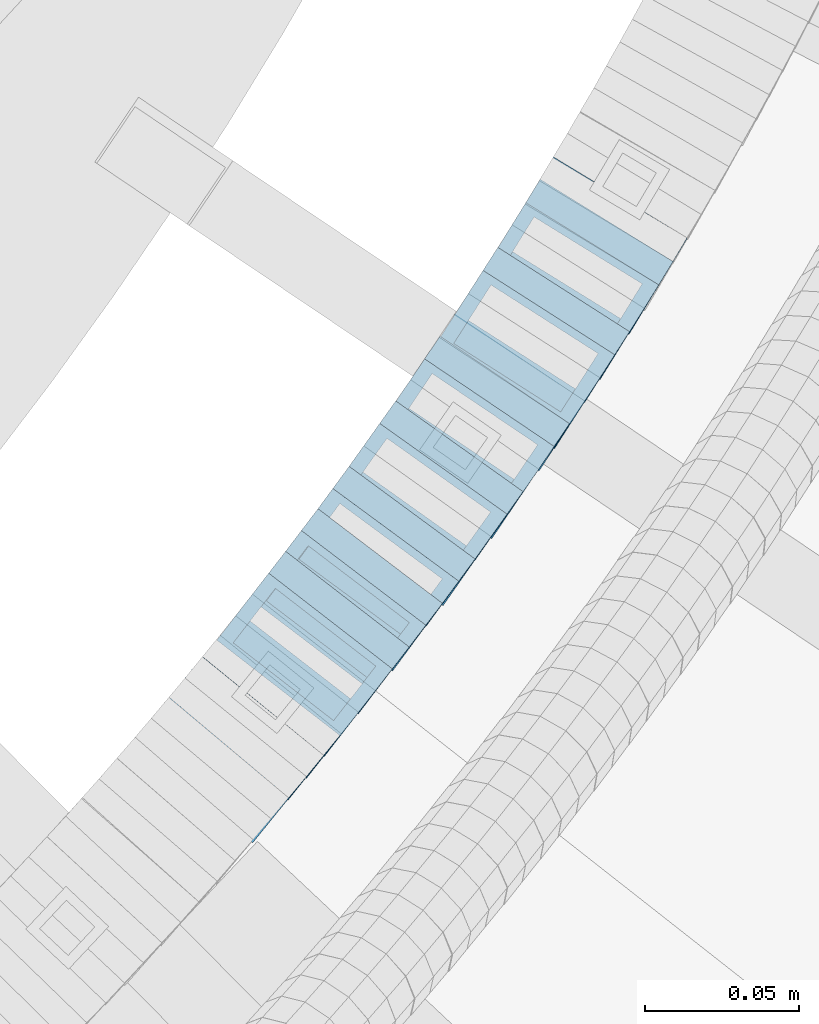
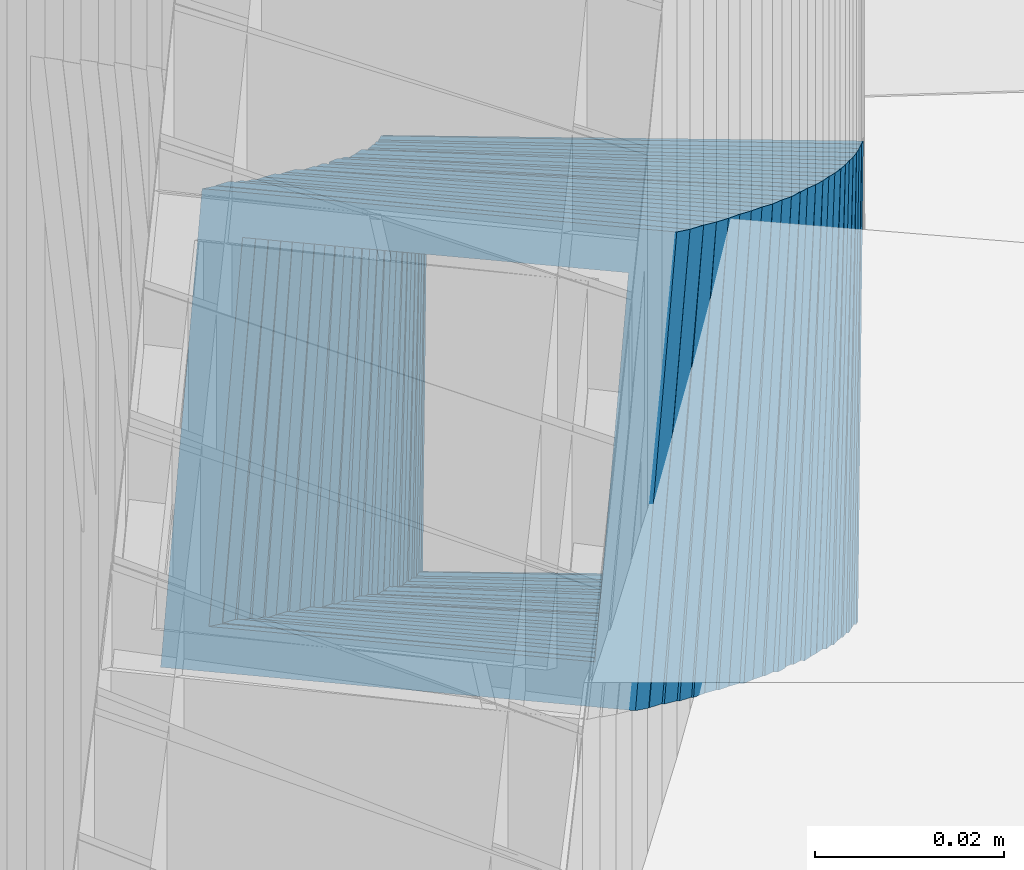
# One storey, part 792 of 975: 24 members.
"""IFC2X3 building model written with IfcOpenShell, lengths in millimetres."""

import ifcopenshell
import ifcopenshell.guid

model = None  # the IFC model being written
_history = None  # IfcOwnerHistory: only IFC2X3 demands one
_inside = {}  # id of a spatial element -> (the spatial element, [elements in it])
_under = {}  # id of a project, library or spatial element -> (it, [spatial elements below it])
_declared = {}  # id of a project -> (the project, [libraries it declares])
_typed = {}  # id of a type object -> (the type object, [elements of that type])
_made_of = {}  # id of a material, layer set ... -> (it, [elements and type objects made of it])


def new_model(schema):
    """Start an empty IFC model of exactly this schema.

    Asked for "IFC4X3", IfcOpenShell would pick the latest addendum, in which some entities
    have other attributes; the version numbers below select the first issue.
    IFC2X3 requires an IfcOwnerHistory on every rooted entity: one is made here for all.
    """
    global model, _history
    if schema == "IFC4X3":
        model = ifcopenshell.file(schema_version=(4, 3, 0, 0))
    else:
        model = ifcopenshell.file(schema=schema)
    _inside.clear()
    _under.clear()
    _declared.clear()
    _typed.clear()
    _made_of.clear()
    _history = None
    if model.schema == "IFC2X3":
        org = make("IfcOrganization", Name="unknown")
        user = make(
            "IfcPersonAndOrganization",
            ThePerson=make("IfcPerson", FamilyName="unknown"),
            TheOrganization=org,
        )
        app = make(
            "IfcApplication",
            ApplicationDeveloper=org,
            Version="unknown",
            ApplicationFullName="unknown",
            ApplicationIdentifier="unknown",
        )
        _history = make(
            "IfcOwnerHistory",
            OwningUser=user,
            OwningApplication=app,
            ChangeAction="ADDED",
            CreationDate=0,
        )
    return model


def make(cls, **values):
    """One entity of the class cls with the attributes given. An attribute that is None is left unset."""
    return model.create_entity(
        cls, **{name: value for name, value in values.items() if value is not None}
    )


def rooted(cls, **values):
    """An entity with a GlobalId (a new one), such as an element, a storey or a relation."""
    return make(cls, GlobalId=ifcopenshell.guid.new(), OwnerHistory=_history, **values)


def si_unit(unit_type, name, prefix=None):
    """IfcSIUnit, for example si_unit("LENGTHUNIT", "METRE", prefix="MILLI")."""
    return make("IfcSIUnit", UnitType=unit_type, Prefix=prefix, Name=name)


def assignment(units):
    """IfcUnitAssignment: the units of a project."""
    return None if units is None else make("IfcUnitAssignment", Units=units)


def point(xyz):
    """IfcCartesianPoint."""
    return None if xyz is None else make("IfcCartesianPoint", Coordinates=xyz)


def direction(xyz):
    """IfcDirection."""
    return None if xyz is None else make("IfcDirection", DirectionRatios=xyz)


def frame(location, z_axis=None, x_axis=None):
    """IfcAxis2Placement3D, a coordinate frame: its origin and axes. An axis left out is left unset."""
    return make(
        "IfcAxis2Placement3D",
        Location=point(location),
        Axis=direction(z_axis),
        RefDirection=direction(x_axis),
    )


def origin_with_axes():
    """The frame at (0, 0, 0) with the z axis (0, 0, 1) and the x axis (1, 0, 0) written out."""
    return frame((0.0, 0.0, 0.0), z_axis=(0.0, 0.0, 1.0), x_axis=(1.0, 0.0, 0.0))


def place(relative_to, where):
    """IfcLocalPlacement: puts the frame where relative to a parent placement (None: the world)."""
    return make(
        "IfcLocalPlacement", PlacementRelTo=relative_to, RelativePlacement=where
    )


def context(
    kind, dimensions, precision=None, world=None, true_north=None, identifier=None
):
    """IfcGeometricRepresentationContext, for example the 3D "Model" context."""
    return make(
        "IfcGeometricRepresentationContext",
        ContextIdentifier=identifier,
        ContextType=kind,
        CoordinateSpaceDimension=dimensions,
        Precision=precision,
        WorldCoordinateSystem=world,
        TrueNorth=true_north,
    )


def subcontext(parent, identifier, kind, view, scale=None):
    """IfcGeometricRepresentationSubContext, for example "Body" below "Model"."""
    return make(
        "IfcGeometricRepresentationSubContext",
        ContextIdentifier=identifier,
        ContextType=kind,
        ParentContext=parent,
        TargetScale=scale,
        TargetView=view,
    )


def project(units=None, contexts=None):
    """IfcProject with its units and contexts."""
    return rooted(
        "IfcProject",
        Name="project",
        RepresentationContexts=contexts,
        UnitsInContext=assignment(units),
    )


def spatial(cls, under=None, at=None, **own):
    """A site, building, storey or space (cls), placed at a placement, below another one or the project."""
    s = rooted(cls, ObjectPlacement=at, **own)
    if under is not None:
        _under.setdefault(under.id(), (under, []))[1].append(s)
    return s


def faces_of(points, faces, orient=None, outer=None):
    """IfcFace entities. A face is a list of loops; a loop is a list of indices into points, from 0.

    orient and outer hold one flag for each loop. By default every Orientation is true, the
    first loop of a face is its IfcFaceOuterBound and the others are IfcFaceBound.
    """
    made = []
    for i, loops in enumerate(faces):
        bounds = []
        for j, loop in enumerate(loops):
            is_outer = j == 0 if outer is None else outer[i][j]
            bounds.append(
                make(
                    "IfcFaceOuterBound" if is_outer else "IfcFaceBound",
                    Bound=make("IfcPolyLoop", Polygon=[points[k] for k in loop]),
                    Orientation=True if orient is None else orient[i][j],
                )
            )
        made.append(make("IfcFace", Bounds=bounds))
    return made


def faceted_brep(points, faces, orient=None, outer=None, voids=None):
    """IfcFacetedBrep: a solid bounded by flat faces; with voids (closed shells), ...WithVoids."""
    shared = [point(p) for p in points]
    hull = make("IfcClosedShell", CfsFaces=faces_of(shared, faces, orient, outer))
    if voids is None:
        return make("IfcFacetedBrep", Outer=hull)
    return make(
        "IfcFacetedBrepWithVoids",
        Outer=hull,
        Voids=[
            make(cls, CfsFaces=faces_of(shared, fs, o, b)) for cls, fs, o, b in voids
        ],
    )


def shape(context_of_items, identifier, shape_type, items):
    """IfcShapeRepresentation: the items that make up one representation, for example the "Body"."""
    return make(
        "IfcShapeRepresentation",
        ContextOfItems=context_of_items,
        RepresentationIdentifier=identifier,
        RepresentationType=shape_type,
        Items=items,
    )


def material(Name=None, Category=None):
    """IfcMaterial."""
    return make("IfcMaterial", Name=Name, Category=Category)


def made_of(thing, what):
    """Note that an element or type object is made of a material, layer set ...; save() writes the relation."""
    if what is not None:
        _made_of.setdefault(what.id(), (what, []))[1].append(thing)
    return thing


def type_object(cls, material=None, **own):
    """A type object (cls), such as IfcWallType, which elements share."""
    return made_of(rooted(cls, **own), material)


def element(
    cls,
    number,
    at=None,
    inside=None,
    cuts=None,
    type_object=None,
    material=None,
    context=None,
    identifier="Body",
    shape_type=None,
    held_by="IfcProductDefinitionShape",
    body=None,
    shapes=None,
    **own,
):
    """One element of the class cls, such as IfcWall. Its Tag is "e" and its number.

    at: its placement. inside: the storey or other place that contains it. cuts: it is an
    opening in that element (IfcRelVoidsElement). A single representation is given by context,
    identifier, shape_type and body (its items); several are given by shapes. held_by: the class
    of the entity that holds the representations. save() writes the other relations.
    """
    e = rooted(cls, Tag="e%d" % number, ObjectPlacement=at, **own)
    if body is not None:
        shapes = [shape(context, identifier, shape_type, body)]
    if shapes is not None:
        e.Representation = make(held_by, Representations=shapes)
    if inside is not None:
        _inside.setdefault(inside.id(), (inside, []))[1].append(e)
    if cuts is not None:
        rooted(
            "IfcRelVoidsElement", RelatingBuildingElement=cuts, RelatedOpeningElement=e
        )
    if type_object is not None:
        _typed.setdefault(type_object.id(), (type_object, []))[1].append(e)
    return made_of(e, material)


def aggregate(whole, parts):
    """IfcRelAggregates: a whole, such as a stair, and the parts it consists of."""
    return rooted("IfcRelAggregates", RelatingObject=whole, RelatedObjects=parts)


def save(model, path):
    """Write the relations noted so far, then the file.

    IfcRelAggregates (storeys below a building ...), IfcRelContainedInSpatialStructure (elements
    in a storey), IfcRelDefinesByType, IfcRelAssociatesMaterial and IfcRelDeclares: one each for
    every whole, place, type object, material and project.
    """
    for whole, parts in _under.values():
        aggregate(whole, parts)
    for where, things in _inside.values():
        rooted(
            "IfcRelContainedInSpatialStructure",
            RelatedElements=things,
            RelatingStructure=where,
        )
    for kind, things in _typed.values():
        rooted("IfcRelDefinesByType", RelatedObjects=things, RelatingType=kind)
    for what, things in _made_of.values():
        rooted("IfcRelAssociatesMaterial", RelatedObjects=things, RelatingMaterial=what)
    for by, libraries in _declared.values():
        rooted("IfcRelDeclares", RelatingContext=by, RelatedDefinitions=libraries)
    model.write(path)


model = new_model("IFC2X3")

# Units and contexts
model_context = context("Model", 3, precision=1e-05, world=origin_with_axes())
body_context = subcontext(model_context, "Body", "Model", "MODEL_VIEW")
ifc_project = project(units=[si_unit("LENGTHUNIT", "METRE", prefix="MILLI"), si_unit("AREAUNIT", "SQUARE_METRE"), si_unit("VOLUMEUNIT", "CUBIC_METRE"), si_unit("MASSUNIT", "GRAM", prefix="KILO"), si_unit("TIMEUNIT", "SECOND"), si_unit("PLANEANGLEUNIT", "RADIAN"), si_unit("SOLIDANGLEUNIT", "STERADIAN"), si_unit("THERMODYNAMICTEMPERATUREUNIT", "DEGREE_CELSIUS"), si_unit("LUMINOUSINTENSITYUNIT", "LUMEN")], contexts=[model_context])

# Site, building, storey
site_placement = place(None, origin_with_axes())
site = spatial("IfcSite", under=ifc_project, at=site_placement, CompositionType="ELEMENT")
building_placement = place(site_placement, origin_with_axes())
building = spatial("IfcBuilding", under=site, at=building_placement, Name="Undefined", CompositionType="ELEMENT")
storey_placement = place(building_placement, origin_with_axes())
storey = spatial("IfcBuildingStorey", under=building, at=storey_placement, Name="Undefined", CompositionType="ELEMENT", Elevation=0.0)

# Members
ifc_material = material()
member_type = type_object("IfcMemberType", Name="HSS2X2X.188_TUBES", PredefinedType="NOTDEFINED")
member_1_placement = place(storey_placement, frame((35807.8947632564, 2509.1009022459, 2485.1295682067), z_axis=(0.776458094539456, -0.630168888016663, -2.13430666917702e-10), x_axis=(-0.527715132084101, -0.650220431103665, 0.546562101087172)))
element("IfcMember", 1, at=member_1_placement, inside=storey, type_object=member_type, material=ifc_material, Name="WALL", ObjectType="HSS2X2X.188_TUBES", context=body_context, shape_type="Brep", body=[
    faceted_brep([(0.0, 20.6374999999753, -20.6375000000298), (0.0, -20.6375000000153, -20.6375000000153), (10.6061303028146, -20.6374999999571, -20.6374999999643), (10.6061303027491, 20.6374999999971, -20.6375000000007), (0.0, -20.6374999999825, 20.6375000000335), (10.6061303027855, -20.6374999999825, 20.6375000000116), (0.0, 20.6375000000116, 20.6375000000189), (10.6061303027236, 20.637499999968, 20.6374999999716), (0.0, 25.3999999999724, -25.4000000000342), (0.0, 25.400000000016, 25.4000000000196), (10.6061303027163, 25.3999999999651, 25.3999999999651), (10.6061303027454, 25.3999999999942, -25.4000000000051), (0.0, -25.399999999976, 25.4000000000378), (10.6061303027891, -25.3999999999796, 25.4000000000124), (0.0, -25.400000000016, -25.4000000000196), (10.6061303028182, -25.3999999999505, -25.3999999999542)], [[[0, 1, 2, 3]], [[1, 4, 5, 2]], [[4, 6, 7, 5]], [[6, 0, 3, 7]], [[8, 9, 10, 11]], [[9, 12, 13, 10]], [[12, 14, 15, 13]], [[14, 8, 11, 15]], [[13, 15, 11, 10], [5, 7, 3, 2]], [[14, 12, 9, 8], [6, 4, 1, 0]]]),
])
for number, where, z_axis, x_axis, name in (
    (2, (35813.8063368493, 2516.39641186203, 2479.22310227178), (0.775435860013196, -0.63142634329397, 1.38674749905476e-10), (-0.533900748146841, -0.655667585180476, 0.533900748146926), "WALL"),
    (3, (35819.2117562662, 2522.96692616996, 2473.57440020284), (0.780868809491731, -0.624695047493549, -4.54620931122918e-10), (-0.524488054089902, -0.65561006811248, 0.54321977109319), "WALL"),
):
    element("IfcMember", number, at=place(storey_placement, frame(where, z_axis=z_axis, x_axis=x_axis)), inside=storey, type_object=member_type, material=ifc_material, Name=name, ObjectType="HSS2X2X.188_TUBES", context=body_context, shape_type="Brep", body=[
        faceted_brep([(0.0, 20.6374999999753, -20.6375000000298), (0.0, -20.6375000000153, -20.6375000000153), (10.6831643251735, -20.6375000000498, -20.6375000000953), (10.6831643252044, 20.637499999988, -20.6375000000226), (0.0, -20.6374999999825, 20.6375000000335), (10.6831643251935, -20.6375000000135, 20.637499999968), (0.0, 20.6375000000116, 20.6375000000189), (10.6831643252244, 20.6375000000226, 20.6375000000407), (0.0, 25.3999999999724, -25.4000000000342), (0.0, 25.400000000016, 25.4000000000196), (10.6831643252317, 25.4000000000306, 25.4000000000597), (10.6831643252044, 25.3999999999905, -25.4000000000196), (0.0, -25.399999999976, 25.4000000000378), (10.6831643251917, -25.400000000016, 25.3999999999614), (0.0, -25.400000000016, -25.4000000000196), (10.6831643251644, -25.400000000056, -25.4000000001179)], [[[0, 1, 2, 3]], [[1, 4, 5, 2]], [[4, 6, 7, 5]], [[6, 0, 3, 7]], [[8, 9, 10, 11]], [[9, 12, 13, 10]], [[12, 14, 15, 13]], [[14, 8, 11, 15]], [[13, 15, 11, 10], [5, 7, 3, 2]], [[14, 12, 9, 8], [6, 4, 1, 0]]]),
    ])
member_2_placement = place(storey_placement, frame((35824.7308560222, 2529.79692098877, 2467.80910192297), z_axis=(0.786318338803255, -0.617821551956298, 5.58256942895241e-11), x_axis=(-0.520305427077897, -0.662206907099037, 0.539225625080648)))
element("IfcMember", 4, at=member_2_placement, inside=storey, type_object=member_type, material=ifc_material, Name="WALL", ObjectType="HSS2X2X.188_TUBES", context=body_context, shape_type="Brep", body=[
    faceted_brep([(0.0, 20.6374999999753, -20.6375000000298), (0.0, -20.6375000000153, -20.6375000000153), (10.5744976239494, -20.6375000000207, -20.6375000000335), (10.5744976239657, 20.6375000000098, -20.637500000008), (0.0, -20.6374999999825, 20.6375000000335), (10.5744976239639, -20.6375000000244, 20.6374999999753), (0.0, 20.6375000000116, 20.6375000000189), (10.5744976239803, 20.6374999999989, 20.6374999999935), (0.0, 25.3999999999724, -25.4000000000342), (0.0, 25.400000000016, 25.4000000000196), (10.5744976239857, 25.4000000000051, 25.4000000000015), (10.5744976239675, 25.4000000000124, -25.4000000000051), (0.0, -25.399999999976, 25.4000000000378), (10.5744976239639, -25.4000000000287, 25.3999999999724), (0.0, -25.400000000016, -25.4000000000196), (10.5744976239494, -25.4000000000215, -25.4000000000378)], [[[0, 1, 2, 3]], [[1, 4, 5, 2]], [[4, 6, 7, 5]], [[6, 0, 3, 7]], [[8, 9, 10, 11]], [[9, 12, 13, 10]], [[12, 14, 15, 13]], [[14, 8, 11, 15]], [[13, 15, 11, 10], [5, 7, 3, 2]], [[14, 12, 9, 8], [6, 4, 1, 0]]]),
])
member_3_placement = place(storey_placement, frame((35830.2500870814, 2536.76887541522, 2462.0545311128), z_axis=(0.790549812362229, -0.612397741810046, -2.3609345589648e-10), x_axis=(-0.517053414058581, -0.667468953075532, 0.535855357060671)))
element("IfcMember", 5, at=member_3_placement, inside=storey, type_object=member_type, material=ifc_material, Name="WALL", ObjectType="HSS2X2X.188_TUBES", context=body_context, shape_type="Brep", body=[
    faceted_brep([(0.0, 20.6374999999753, -20.6375000000298), (0.0, -20.6375000000153, -20.6375000000153), (10.6395488625676, -20.6374999999771, -20.6374999999716), (10.6395488625531, 20.6374999999916, -20.6375000000189), (0.0, -20.6374999999825, 20.6375000000335), (10.6395488625731, -20.6374999999844, 20.6375000000153), (0.0, 20.6375000000116, 20.6375000000189), (10.6395488625585, 20.6374999999825, 20.637499999968), (0.0, 25.3999999999724, -25.4000000000342), (0.0, 25.400000000016, 25.4000000000196), (10.6395488625567, 25.3999999999778, 25.3999999999614), (10.6395488625494, 25.3999999999887, -25.4000000000233), (0.0, -25.399999999976, 25.4000000000378), (10.6395488625749, -25.3999999999851, 25.400000000016), (0.0, -25.400000000016, -25.4000000000196), (10.6395488625658, -25.399999999976, -25.3999999999687)], [[[0, 1, 2, 3]], [[1, 4, 5, 2]], [[4, 6, 7, 5]], [[6, 0, 3, 7]], [[8, 9, 10, 11]], [[9, 12, 13, 10]], [[12, 14, 15, 13]], [[14, 8, 11, 15]], [[13, 15, 11, 10], [5, 7, 3, 2]], [[14, 12, 9, 8], [6, 4, 1, 0]]]),
])
member_4_placement = place(storey_placement, frame((35835.6466305097, 2543.7353223863, 2456.36268787828), z_axis=(0.790549812362229, -0.612397741810046, -2.3609345589648e-10), x_axis=(-0.514445739102231, -0.664102681131874, 0.542506415107707)))
element("IfcMember", 6, at=member_4_placement, inside=storey, type_object=member_type, material=ifc_material, Name="WALL", ObjectType="HSS2X2X.188_TUBES", context=body_context, shape_type="Brep", body=[
    faceted_brep([(0.0, 20.6374999999753, -20.6375000000298), (0.0, -20.6375000000153, -20.6375000000153), (10.6906501205649, -20.6374999999844, -20.637499999968), (10.690650120574, 20.6375000000098, -20.6374999999716), (0.0, -20.6374999999825, 20.6375000000335), (10.6906501205467, -20.6374999999844, 20.637500000008), (0.0, 20.6375000000116, 20.6375000000189), (10.6906501205558, 20.637500000008, 20.6375000000007), (0.0, 25.3999999999724, -25.4000000000342), (0.0, 25.400000000016, 25.4000000000196), (10.6906501205522, 25.4000000000087, 25.3999999999978), (10.6906501205813, 25.4000000000124, -25.3999999999651), (0.0, -25.399999999976, 25.4000000000378), (10.6906501205431, -25.3999999999833, 25.4000000000051), (0.0, -25.400000000016, -25.4000000000196), (10.6906501205704, -25.3999999999833, -25.3999999999614)], [[[0, 1, 2, 3]], [[1, 4, 5, 2]], [[4, 6, 7, 5]], [[6, 0, 3, 7]], [[8, 9, 10, 11]], [[9, 12, 13, 10]], [[12, 14, 15, 13]], [[14, 8, 11, 15]], [[13, 15, 11, 10], [5, 7, 3, 2]], [[14, 12, 9, 8], [6, 4, 1, 0]]]),
])
member_5_placement = place(storey_placement, frame((35841.0687324626, 2550.66429848711, 2450.59658430275), z_axis=(0.795946119300868, -0.605367471185798, -2.1885171008762e-11), x_axis=(-0.5101154189932, -0.670707309990796, 0.538455163992604)))
element("IfcMember", 7, at=member_5_placement, inside=storey, type_object=member_type, material=ifc_material, Name="WALL", ObjectType="HSS2X2X.188_TUBES", context=body_context, shape_type="Brep", body=[
    faceted_brep([(0.0, 20.6374999999753, -20.6375000000298), (0.0, -20.6375000000153, -20.6375000000153), (10.5948100501191, -20.6375000000335, -20.6375000000844), (10.5948100501555, 20.6374999999971, -20.6375000000116), (0.0, -20.6374999999825, 20.6375000000335), (10.5948100501446, -20.6375000000098, 20.6374999999571), (0.0, 20.6375000000116, 20.6375000000189), (10.5948100501828, 20.6375000000189, 20.6375000000298), (0.0, 25.3999999999724, -25.4000000000342), (0.0, 25.400000000016, 25.4000000000196), (10.5948100501919, 25.4000000000251, 25.4000000000451), (10.5948100501591, 25.3999999999978, -25.4000000000051), (0.0, -25.399999999976, 25.4000000000378), (10.5948100501482, -25.4000000000106, 25.3999999999578), (0.0, -25.400000000016, -25.4000000000196), (10.5948100501118, -25.4000000000378, -25.400000000096)], [[[0, 1, 2, 3]], [[1, 4, 5, 2]], [[4, 6, 7, 5]], [[6, 0, 3, 7]], [[8, 9, 10, 11]], [[9, 12, 13, 10]], [[12, 14, 15, 13]], [[14, 8, 11, 15]], [[13, 15, 11, 10], [5, 7, 3, 2]], [[14, 12, 9, 8], [6, 4, 1, 0]]]),
])
member_6_placement = place(storey_placement, frame((35846.3663775189, 2557.62972069072, 2444.90557094411), z_axis=(0.795946119300868, -0.605367471185798, -2.1885171008762e-11), x_axis=(-0.507517900160967, -0.667292054211754, 0.545111819172966)))
element("IfcMember", 8, at=member_6_placement, inside=storey, type_object=member_type, material=ifc_material, Name="WALL", ObjectType="HSS2X2X.188_TUBES", context=body_context, shape_type="Brep", body=[
    faceted_brep([(0.0, 20.6374999999753, -20.6375000000298), (0.0, -20.6375000000153, -20.6375000000153), (10.6395488625676, -20.6374999999771, -20.6374999999716), (10.6395488625531, 20.6374999999916, -20.6375000000189), (0.0, -20.6374999999825, 20.6375000000335), (10.6395488625731, -20.6374999999844, 20.6375000000153), (0.0, 20.6375000000116, 20.6375000000189), (10.6395488625585, 20.6374999999825, 20.637499999968), (0.0, 25.3999999999724, -25.4000000000342), (0.0, 25.400000000016, 25.4000000000196), (10.6395488625567, 25.3999999999778, 25.3999999999614), (10.6395488625494, 25.3999999999887, -25.4000000000233), (0.0, -25.399999999976, 25.4000000000378), (10.6395488625749, -25.3999999999851, 25.400000000016), (0.0, -25.400000000016, -25.4000000000196), (10.6395488625658, -25.399999999976, -25.3999999999687)], [[[0, 1, 2, 3]], [[1, 4, 5, 2]], [[4, 6, 7, 5]], [[6, 0, 3, 7]], [[8, 9, 10, 11]], [[9, 12, 13, 10]], [[12, 14, 15, 13]], [[14, 8, 11, 15]], [[13, 15, 11, 10], [5, 7, 3, 2]], [[14, 12, 9, 8], [6, 4, 1, 0]]]),
])
member_7_placement = place(storey_placement, frame((35851.7148431369, 2564.53474188251, 2439.08259582463), z_axis=(0.805336883996211, -0.592817428282328, 1.46393176692072e-10), x_axis=(-0.499866553846756, -0.679063997791999, 0.5375923318353)))
element("IfcMember", 9, at=member_7_placement, inside=storey, type_object=member_type, material=ifc_material, Name="WALL", ObjectType="HSS2X2X.188_TUBES", context=body_context, shape_type="Brep", body=[
    faceted_brep([(0.0, 20.6374999999753, -20.6375000000298), (0.0, -20.6375000000153, -20.6375000000153), (10.6004716875832, -20.6375000000153, -20.6375000000553), (10.6004716875814, 20.6374999999898, -20.6375000000444), (0.0, -20.6374999999825, 20.6375000000335), (10.6004716876068, -20.6375000000044, 20.6374999999862), (0.0, 20.6375000000116, 20.6375000000189), (10.6004716876032, 20.6374999999989, 20.6374999999971), (0.0, 25.3999999999724, -25.4000000000342), (0.0, 25.400000000016, 25.4000000000196), (10.600471687605, 25.4000000000015, 25.4000000000051), (10.6004716875814, 25.3999999999869, -25.4000000000487), (0.0, -25.399999999976, 25.4000000000378), (10.6004716876068, -25.4000000000015, 25.3999999999905), (0.0, -25.400000000016, -25.4000000000196), (10.6004716875814, -25.4000000000178, -25.4000000000669)], [[[0, 1, 2, 3]], [[1, 4, 5, 2]], [[4, 6, 7, 5]], [[6, 0, 3, 7]], [[8, 9, 10, 11]], [[9, 12, 13, 10]], [[12, 14, 15, 13]], [[14, 8, 11, 15]], [[13, 15, 11, 10], [5, 7, 3, 2]], [[14, 12, 9, 8], [6, 4, 1, 0]]]),
])
member_8_placement = place(storey_placement, frame((35856.9146374682, 2571.59861342687, 2433.39130711656), z_axis=(0.805336883996211, -0.592817428282328, 1.46393176692072e-10), x_axis=(-0.497329311996823, -0.675617177995555, 0.54424717199641)))
element("IfcMember", 10, at=member_8_placement, inside=storey, type_object=member_type, material=ifc_material, Name="WALL", ObjectType="HSS2X2X.188_TUBES", context=body_context, shape_type="Brep", body=[
    faceted_brep([(0.0, 20.6374999999753, -20.6375000000298), (0.0, -20.6375000000153, -20.6375000000153), (10.6625512894789, -20.6374999999625, -20.6374999999389), (10.6625512893879, 20.6374999999789, -20.6375000000371), (0.0, -20.6374999999825, 20.6375000000335), (10.6625512894352, -20.6374999999989, 20.6375000000153), (0.0, 20.6375000000116, 20.6375000000189), (10.6625512893443, 20.6374999999443, 20.6374999999134), (0.0, 25.3999999999724, -25.4000000000342), (0.0, 25.400000000016, 25.4000000000196), (10.6625512893297, 25.3999999999342, 25.3999999998996), (10.6625512893916, 25.399999999976, -25.4000000000415), (0.0, -25.399999999976, 25.4000000000378), (10.6625512894389, -25.399999999996, 25.400000000016), (0.0, -25.400000000016, -25.4000000000196), (10.6625512894971, -25.3999999999523, -25.3999999999214)], [[[0, 1, 2, 3]], [[1, 4, 5, 2]], [[4, 6, 7, 5]], [[6, 0, 3, 7]], [[8, 9, 10, 11]], [[9, 12, 13, 10]], [[12, 14, 15, 13]], [[14, 8, 11, 15]], [[13, 15, 11, 10], [5, 7, 3, 2]], [[14, 12, 9, 8], [6, 4, 1, 0]]]),
])
member_9_placement = place(storey_placement, frame((35862.3400156094, 2578.91761425818, 2427.52723857277), z_axis=(0.809215172970906, -0.587512386110852, 6.74795046506914e-11), x_axis=(-0.496673752074824, -0.684097809102968, 0.5341585640804)))
element("IfcMember", 11, at=member_9_placement, inside=storey, type_object=member_type, material=ifc_material, Name="WALL", ObjectType="HSS2X2X.188_TUBES", context=body_context, shape_type="Brep", body=[
    faceted_brep([(0.0, 20.6374999999753, -20.6375000000298), (0.0, -20.6375000000153, -20.6375000000153), (10.6709887076922, -20.6374999999844, -20.6374999999825), (10.6709887076995, 20.6375000000171, -20.6374999999753), (0.0, -20.6374999999825, 20.6375000000335), (10.6709887076922, -20.6374999999971, 20.6375000000153), (0.0, 20.6375000000116, 20.6375000000189), (10.6709887076941, 20.6375000000025, 20.6375000000189), (0.0, 25.3999999999724, -25.4000000000342), (0.0, 25.400000000016, 25.4000000000196), (10.6709887076959, 25.3999999999996, 25.4000000000233), (10.6709887077013, 25.4000000000178, -25.3999999999724), (0.0, -25.399999999976, 25.4000000000378), (10.6709887076904, -25.3999999999978, 25.400000000016), (0.0, -25.400000000016, -25.4000000000196), (10.6709887076959, -25.3999999999796, -25.3999999999796)], [[[0, 1, 2, 3]], [[1, 4, 5, 2]], [[4, 6, 7, 5]], [[6, 0, 3, 7]], [[8, 9, 10, 11]], [[9, 12, 13, 10]], [[12, 14, 15, 13]], [[14, 8, 11, 15]], [[13, 15, 11, 10], [5, 7, 3, 2]], [[14, 12, 9, 8], [6, 4, 1, 0]]]),
])
member_10_placement = place(storey_placement, frame((35867.3010982291, 2585.59554283684, 2421.90714083713), z_axis=(0.819759137986819, -0.572708438637941, -1.85146291187266e-10), x_axis=(-0.482357124928893, -0.690432747898275, 0.539105021920562)))
element("IfcMember", 12, at=member_10_placement, inside=storey, type_object=member_type, material=ifc_material, Name="WALL", ObjectType="HSS2X2X.188_TUBES", context=body_context, shape_type="Brep", body=[
    faceted_brep([(0.0, 20.6374999999753, -20.6375000000298), (0.0, -20.6375000000153, -20.6375000000153), (10.5744976239494, -20.6375000000207, -20.6375000000335), (10.5744976239657, 20.6375000000098, -20.637500000008), (0.0, -20.6374999999825, 20.6375000000335), (10.5744976239639, -20.6375000000244, 20.6374999999753), (0.0, 20.6375000000116, 20.6375000000189), (10.5744976239803, 20.6374999999989, 20.6374999999935), (0.0, 25.3999999999724, -25.4000000000342), (0.0, 25.400000000016, 25.4000000000196), (10.5744976239857, 25.4000000000051, 25.4000000000015), (10.5744976239675, 25.4000000000124, -25.4000000000051), (0.0, -25.399999999976, 25.4000000000378), (10.5744976239639, -25.4000000000287, 25.3999999999724), (0.0, -25.400000000016, -25.4000000000196), (10.5744976239494, -25.4000000000215, -25.4000000000378)], [[[0, 1, 2, 3]], [[1, 4, 5, 2]], [[4, 6, 7, 5]], [[6, 0, 3, 7]], [[8, 9, 10, 11]], [[9, 12, 13, 10]], [[12, 14, 15, 13]], [[14, 8, 11, 15]], [[13, 15, 11, 10], [5, 7, 3, 2]], [[14, 12, 9, 8], [6, 4, 1, 0]]]),
])
member_11_placement = place(storey_placement, frame((35872.4709867625, 2593.07097107054, 2416.17557518153), z_axis=(0.814486661844144, -0.580182279700082, -9.95614755083806e-11), x_axis=(-0.487088716912269, -0.683797621876688, 0.543291260902055)))
element("IfcMember", 13, at=member_11_placement, inside=storey, type_object=member_type, material=ifc_material, Name="WALL", ObjectType="HSS2X2X.188_TUBES", context=body_context, shape_type="Brep", body=[
    faceted_brep([(0.0, 20.6374999999753, -20.6375000000298), (0.0, -20.6375000000153, -20.6375000000153), (10.6831643251735, -20.6375000000498, -20.6375000000953), (10.6831643252044, 20.637499999988, -20.6375000000226), (0.0, -20.6374999999825, 20.6375000000335), (10.6831643251935, -20.6375000000135, 20.637499999968), (0.0, 20.6375000000116, 20.6375000000189), (10.6831643252244, 20.6375000000226, 20.6375000000407), (0.0, 25.3999999999724, -25.4000000000342), (0.0, 25.400000000016, 25.4000000000196), (10.6831643252317, 25.4000000000306, 25.4000000000597), (10.6831643252044, 25.3999999999905, -25.4000000000196), (0.0, -25.399999999976, 25.4000000000378), (10.6831643251917, -25.400000000016, 25.3999999999614), (0.0, -25.400000000016, -25.4000000000196), (10.6831643251644, -25.400000000056, -25.4000000001179)], [[[0, 1, 2, 3]], [[1, 4, 5, 2]], [[4, 6, 7, 5]], [[6, 0, 3, 7]], [[8, 9, 10, 11]], [[9, 12, 13, 10]], [[12, 14, 15, 13]], [[14, 8, 11, 15]], [[13, 15, 11, 10], [5, 7, 3, 2]], [[14, 12, 9, 8], [6, 4, 1, 0]]]),
])
member_12_placement = place(storey_placement, frame((35877.6010982291, 2600.19554283684, 2410.40714083713), z_axis=(0.819759137986819, -0.572708438637941, -1.85146291187266e-10), x_axis=(-0.482357124928893, -0.690432747898275, 0.539105021920562)))
element("IfcMember", 14, at=member_12_placement, inside=storey, type_object=member_type, material=ifc_material, Name="WALL", ObjectType="HSS2X2X.188_TUBES", context=body_context, shape_type="Brep", body=[
    faceted_brep([(0.0, 20.6374999999753, -20.6375000000298), (0.0, -20.6375000000153, -20.6375000000153), (10.5744976239494, -20.6375000000207, -20.6375000000335), (10.5744976239657, 20.6375000000098, -20.637500000008), (0.0, -20.6374999999825, 20.6375000000335), (10.5744976239639, -20.6375000000244, 20.6374999999753), (0.0, 20.6375000000116, 20.6375000000189), (10.5744976239803, 20.6374999999989, 20.6374999999935), (0.0, 25.3999999999724, -25.4000000000342), (0.0, 25.400000000016, 25.4000000000196), (10.5744976239857, 25.4000000000051, 25.4000000000015), (10.5744976239675, 25.4000000000124, -25.4000000000051), (0.0, -25.399999999976, 25.4000000000378), (10.5744976239639, -25.4000000000287, 25.3999999999724), (0.0, -25.400000000016, -25.4000000000196), (10.5744976239494, -25.4000000000215, -25.4000000000378)], [[[0, 1, 2, 3]], [[1, 4, 5, 2]], [[4, 6, 7, 5]], [[6, 0, 3, 7]], [[8, 9, 10, 11]], [[9, 12, 13, 10]], [[12, 14, 15, 13]], [[14, 8, 11, 15]], [[13, 15, 11, 10], [5, 7, 3, 2]], [[14, 12, 9, 8], [6, 4, 1, 0]]]),
])
member_13_placement = place(storey_placement, frame((35882.568517396, 2607.17148948279, 2404.6891891751), z_axis=(0.828588968904653, -0.559857410962403, 1.41858436109032e-11), x_axis=(-0.471929177978198, -0.698455183967554, 0.537999262975028)))
element("IfcMember", 15, at=member_13_placement, inside=storey, type_object=member_type, material=ifc_material, Name="WALL", ObjectType="HSS2X2X.188_TUBES", context=body_context, shape_type="Brep", body=[
    faceted_brep([(0.0, 20.6374999999753, -20.6375000000298), (0.0, -20.6375000000153, -20.6375000000153), (10.5948100501191, -20.6375000000335, -20.6375000000844), (10.5948100501555, 20.6374999999971, -20.6375000000116), (0.0, -20.6374999999825, 20.6375000000335), (10.5948100501446, -20.6375000000098, 20.6374999999571), (0.0, 20.6375000000116, 20.6375000000189), (10.5948100501828, 20.6375000000189, 20.6375000000298), (0.0, 25.3999999999724, -25.4000000000342), (0.0, 25.400000000016, 25.4000000000196), (10.5948100501919, 25.4000000000251, 25.4000000000451), (10.5948100501591, 25.3999999999978, -25.4000000000051), (0.0, -25.399999999976, 25.4000000000378), (10.5948100501482, -25.4000000000106, 25.3999999999578), (0.0, -25.400000000016, -25.4000000000196), (10.5948100501118, -25.4000000000378, -25.400000000096)], [[[0, 1, 2, 3]], [[1, 4, 5, 2]], [[4, 6, 7, 5]], [[6, 0, 3, 7]], [[8, 9, 10, 11]], [[9, 12, 13, 10]], [[12, 14, 15, 13]], [[14, 8, 11, 15]], [[13, 15, 11, 10], [5, 7, 3, 2]], [[14, 12, 9, 8], [6, 4, 1, 0]]]),
])
member_14_placement = place(storey_placement, frame((35887.4738708098, 2614.4314125353, 2398.99803033736), z_axis=(0.828588968904653, -0.559857410962403, 1.41858436109032e-11), x_axis=(-0.469530142078345, -0.694904609116148, 0.54465496409105)))
element("IfcMember", 16, at=member_14_placement, inside=storey, type_object=member_type, material=ifc_material, Name="WALL", ObjectType="HSS2X2X.188_TUBES", context=body_context, shape_type="Brep", body=[
    faceted_brep([(0.0, 20.6374999999753, -20.6375000000298), (0.0, -20.6375000000153, -20.6375000000153), (10.648004507897, -20.6374999999862, -20.637499999968), (10.6480045078188, 20.6374999999771, -20.6375000000808), (0.0, -20.6374999999825, 20.6375000000335), (10.6480045079406, -20.6374999999698, 20.6375000001062), (0.0, 20.6375000000116, 20.6375000000189), (10.6480045078679, 20.6374999999935, 20.6375000000007), (0.0, 25.3999999999724, -25.4000000000342), (0.0, 25.400000000016, 25.4000000000196), (10.6480045078661, 25.3999999999905, 25.4000000000015), (10.648004507806, 25.3999999999705, -25.4000000000997), (0.0, -25.399999999976, 25.4000000000378), (10.6480045079552, -25.3999999999633, 25.4000000001288), (0.0, -25.400000000016, -25.4000000000196), (10.6480045078988, -25.3999999999814, -25.3999999999651)], [[[0, 1, 2, 3]], [[1, 4, 5, 2]], [[4, 6, 7, 5]], [[6, 0, 3, 7]], [[8, 9, 10, 11]], [[9, 12, 13, 10]], [[12, 14, 15, 13]], [[14, 8, 11, 15]], [[13, 15, 11, 10], [5, 7, 3, 2]], [[14, 12, 9, 8], [6, 4, 1, 0]]]),
])
member_15_placement = place(storey_placement, frame((35892.568517396, 2621.97148948279, 2393.1891891751), z_axis=(0.828588968904653, -0.559857410962403, 1.41858436109032e-11), x_axis=(-0.471929177978198, -0.698455183967554, 0.537999262975028)))
element("IfcMember", 17, at=member_15_placement, inside=storey, type_object=member_type, material=ifc_material, Name="WALL", ObjectType="HSS2X2X.188_TUBES", context=body_context, shape_type="Brep", body=[
    faceted_brep([(0.0, 20.6374999999753, -20.6375000000298), (0.0, -20.6375000000153, -20.6375000000153), (10.5948100501191, -20.6375000000335, -20.6375000000844), (10.5948100501555, 20.6374999999971, -20.6375000000116), (0.0, -20.6374999999825, 20.6375000000335), (10.5948100501446, -20.6375000000098, 20.6374999999571), (0.0, 20.6375000000116, 20.6375000000189), (10.5948100501828, 20.6375000000189, 20.6375000000298), (0.0, 25.3999999999724, -25.4000000000342), (0.0, 25.400000000016, 25.4000000000196), (10.5948100501919, 25.4000000000251, 25.4000000000451), (10.5948100501591, 25.3999999999978, -25.4000000000051), (0.0, -25.399999999976, 25.4000000000378), (10.5948100501482, -25.4000000000106, 25.3999999999578), (0.0, -25.400000000016, -25.4000000000196), (10.5948100501118, -25.4000000000378, -25.400000000096)], [[[0, 1, 2, 3]], [[1, 4, 5, 2]], [[4, 6, 7, 5]], [[6, 0, 3, 7]], [[8, 9, 10, 11]], [[9, 12, 13, 10]], [[12, 14, 15, 13]], [[14, 8, 11, 15]], [[13, 15, 11, 10], [5, 7, 3, 2]], [[14, 12, 9, 8], [6, 4, 1, 0]]]),
])
member_16_placement = place(storey_placement, frame((35897.443647997, 2629.05178994912, 2387.46985947384), z_axis=(0.837166200072577, -0.546948583923609, -6.59451870888006e-11), x_axis=(-0.461463976956379, -0.706322413933349, 0.536805034949347)))
element("IfcMember", 18, at=member_16_placement, inside=storey, type_object=member_type, material=ifc_material, Name="WALL", ObjectType="HSS2X2X.188_TUBES", context=body_context, shape_type="Brep", body=[
    faceted_brep([(0.0, 20.6374999999753, -20.6375000000298), (0.0, -20.6375000000153, -20.6375000000153), (10.6216759506497, -20.637499999968, -20.6374999999534), (10.6216759506497, 20.6375000000262, -20.6374999999643), (0.0, -20.6374999999825, 20.6375000000335), (10.6216759506169, -20.6374999999935, 20.637500000008), (0.0, 20.6375000000116, 20.6375000000189), (10.6216759506242, 20.6375000000007, 20.6374999999971), (0.0, 25.3999999999724, -25.4000000000342), (0.0, 25.400000000016, 25.4000000000196), (10.6216759506169, 25.3999999999978, 25.3999999999869), (10.6216759506533, 25.4000000000269, -25.3999999999614), (0.0, -25.399999999976, 25.4000000000378), (10.6216759506242, -25.3999999999942, 25.4000000000051), (0.0, -25.400000000016, -25.4000000000196), (10.6216759506569, -25.3999999999614, -25.3999999999432)], [[[0, 1, 2, 3]], [[1, 4, 5, 2]], [[4, 6, 7, 5]], [[6, 0, 3, 7]], [[8, 9, 10, 11]], [[9, 12, 13, 10]], [[12, 14, 15, 13]], [[14, 8, 11, 15]], [[13, 15, 11, 10], [5, 7, 3, 2]], [[14, 12, 9, 8], [6, 4, 1, 0]]]),
])
member_17_placement = place(storey_placement, frame((35902.1897999782, 2636.23193005508, 2381.80753289956), z_axis=(0.842271400700033, -0.539053696363177, 2.99316525342875e-10), x_axis=(-0.454003483147113, -0.709380442229661, 0.539129136174572)))
element("IfcMember", 19, at=member_17_placement, inside=storey, type_object=member_type, material=ifc_material, Name="WALL", ObjectType="HSS2X2X.188_TUBES", context=body_context, shape_type="Brep", body=[
    faceted_brep([(0.0, 20.6374999999753, -20.6375000000298), (0.0, -20.6375000000153, -20.6375000000153), (10.5744976239494, -20.6375000000207, -20.6375000000335), (10.5744976239657, 20.6375000000098, -20.637500000008), (0.0, -20.6374999999825, 20.6375000000335), (10.5744976239639, -20.6375000000244, 20.6374999999753), (0.0, 20.6375000000116, 20.6375000000189), (10.5744976239803, 20.6374999999989, 20.6374999999935), (0.0, 25.3999999999724, -25.4000000000342), (0.0, 25.400000000016, 25.4000000000196), (10.5744976239857, 25.4000000000051, 25.4000000000015), (10.5744976239675, 25.4000000000124, -25.4000000000051), (0.0, -25.399999999976, 25.4000000000378), (10.5744976239639, -25.4000000000287, 25.3999999999724), (0.0, -25.400000000016, -25.4000000000196), (10.5744976239494, -25.4000000000215, -25.4000000000378)], [[[0, 1, 2, 3]], [[1, 4, 5, 2]], [[4, 6, 7, 5]], [[6, 0, 3, 7]], [[8, 9, 10, 11]], [[9, 12, 13, 10]], [[12, 14, 15, 13]], [[14, 8, 11, 15]], [[13, 15, 11, 10], [5, 7, 3, 2]], [[14, 12, 9, 8], [6, 4, 1, 0]]]),
])
member_18_placement = place(storey_placement, frame((35906.8986382962, 2643.58948992694, 2376.11673456788), z_axis=(0.842271400700033, -0.539053696363177, 2.99316525342875e-10), x_axis=(-0.45168594109063, -0.705759283141711, 0.54578717910956)))
element("IfcMember", 20, at=member_18_placement, inside=storey, type_object=member_type, material=ifc_material, Name="WALL", ObjectType="HSS2X2X.188_TUBES", context=body_context, shape_type="Brep", body=[
    faceted_brep([(0.0, 20.6374999999753, -20.6375000000298), (0.0, -20.6375000000153, -20.6375000000153), (10.6348483769107, -20.637499999988, -20.6374999999825), (10.6348483768415, 20.6374999999734, -20.6375000001026), (0.0, -20.6374999999825, 20.6375000000335), (10.6348483769852, -20.6374999999589, 20.6375000001462), (0.0, 20.6375000000116, 20.6375000000189), (10.6348483769161, 20.6375000000044, 20.6375000000226), (0.0, 25.3999999999724, -25.4000000000342), (0.0, 25.400000000016, 25.4000000000196), (10.6348483769179, 25.4000000000015, 25.4000000000233), (10.6348483768288, 25.3999999999669, -25.4000000001324), (0.0, -25.399999999976, 25.4000000000378), (10.6348483769998, -25.3999999999505, 25.4000000001688), (0.0, -25.400000000016, -25.4000000000196), (10.6348483769107, -25.3999999999887, -25.3999999999833)], [[[0, 1, 2, 3]], [[1, 4, 5, 2]], [[4, 6, 7, 5]], [[6, 0, 3, 7]], [[8, 9, 10, 11]], [[9, 12, 13, 10]], [[12, 14, 15, 13]], [[14, 8, 11, 15]], [[13, 15, 11, 10], [5, 7, 3, 2]], [[14, 12, 9, 8], [6, 4, 1, 0]]]),
])
member_19_placement = place(storey_placement, frame((35911.8262719418, 2651.23674646263, 2370.24919433073), z_axis=(0.845488903158904, -0.533992991185421, 4.56034285889473e-11), x_axis=(-0.450967712132293, -0.714032211209294, 0.53552415815697)))
element("IfcMember", 21, at=member_19_placement, inside=storey, type_object=member_type, material=ifc_material, Name="WALL", ObjectType="HSS2X2X.188_TUBES", context=body_context, shape_type="Brep", body=[
    faceted_brep([(0.0, 20.6374999999753, -20.6375000000298), (0.0, -20.6375000000153, -20.6375000000153), (10.6395488625676, -20.6374999999771, -20.6374999999716), (10.6395488625531, 20.6374999999916, -20.6375000000189), (0.0, -20.6374999999825, 20.6375000000335), (10.6395488625731, -20.6374999999844, 20.6375000000153), (0.0, 20.6375000000116, 20.6375000000189), (10.6395488625585, 20.6374999999825, 20.637499999968), (0.0, 25.3999999999724, -25.4000000000342), (0.0, 25.400000000016, 25.4000000000196), (10.6395488625567, 25.3999999999778, 25.3999999999614), (10.6395488625494, 25.3999999999887, -25.4000000000233), (0.0, -25.399999999976, 25.4000000000378), (10.6395488625749, -25.3999999999851, 25.400000000016), (0.0, -25.400000000016, -25.4000000000196), (10.6395488625658, -25.399999999976, -25.3999999999687)], [[[0, 1, 2, 3]], [[1, 4, 5, 2]], [[4, 6, 7, 5]], [[6, 0, 3, 7]], [[8, 9, 10, 11]], [[9, 12, 13, 10]], [[12, 14, 15, 13]], [[14, 8, 11, 15]], [[13, 15, 11, 10], [5, 7, 3, 2]], [[14, 12, 9, 8], [6, 4, 1, 0]]]),
])
for number, where, z_axis, x_axis, name in (
    (22, (35916.4778537743, 2658.51592122019, 2364.5856958392), (0.850503552704201, -0.525969302181727, 1.97831468540244e-10), (-0.443435693790258, -0.71704495166102, 0.537783713745776), "WALL"),
    (23, (35921.1778537743, 2666.11592122021, 2358.8856958392), (0.850503552704201, -0.525969302181727, 1.97831468540244e-10), (-0.443435693790258, -0.71704495166102, 0.537783713745776), "WALL"),
):
    element("IfcMember", number, at=place(storey_placement, frame(where, z_axis=z_axis, x_axis=x_axis)), inside=storey, type_object=member_type, material=ifc_material, Name=name, ObjectType="HSS2X2X.188_TUBES", context=body_context, shape_type="Brep", body=[
        faceted_brep([(0.0, 20.6374999999753, -20.6375000000298), (0.0, -20.6375000000153, -20.6375000000153), (10.6004716875832, -20.6375000000153, -20.6375000000553), (10.6004716875814, 20.6374999999898, -20.6375000000444), (0.0, -20.6374999999825, 20.6375000000335), (10.6004716876068, -20.6375000000044, 20.6374999999862), (0.0, 20.6375000000116, 20.6375000000189), (10.6004716876032, 20.6374999999989, 20.6374999999971), (0.0, 25.3999999999724, -25.4000000000342), (0.0, 25.400000000016, 25.4000000000196), (10.600471687605, 25.4000000000015, 25.4000000000051), (10.6004716875814, 25.3999999999869, -25.4000000000487), (0.0, -25.399999999976, 25.4000000000378), (10.6004716876068, -25.4000000000015, 25.3999999999905), (0.0, -25.400000000016, -25.4000000000196), (10.6004716875814, -25.4000000000178, -25.4000000000669)], [[[0, 1, 2, 3]], [[1, 4, 5, 2]], [[4, 6, 7, 5]], [[6, 0, 3, 7]], [[8, 9, 10, 11]], [[9, 12, 13, 10]], [[12, 14, 15, 13]], [[14, 8, 11, 15]], [[13, 15, 11, 10], [5, 7, 3, 2]], [[14, 12, 9, 8], [6, 4, 1, 0]]]),
    ])
member_20_placement = place(storey_placement, frame((35925.6454442582, 2673.2468486193, 2353.23158075646), z_axis=(0.855500079109598, -0.517802679254822, 1.05275375972269e-10), x_axis=(-0.433576554102022, -0.716343872168833, 0.54668348112887)))
element("IfcMember", 24, at=member_20_placement, inside=storey, type_object=member_type, material=ifc_material, Name="WALL", ObjectType="HSS2X2X.188_TUBES", context=body_context, shape_type="Brep", body=[
    faceted_brep([(0.0, 20.6374999999753, -20.6375000000298), (0.0, -20.6375000000153, -20.6375000000153), (10.6061303028146, -20.6374999999571, -20.6374999999643), (10.6061303027491, 20.6374999999971, -20.6375000000007), (0.0, -20.6374999999825, 20.6375000000335), (10.6061303027855, -20.6374999999825, 20.6375000000116), (0.0, 20.6375000000116, 20.6375000000189), (10.6061303027236, 20.637499999968, 20.6374999999716), (0.0, 25.3999999999724, -25.4000000000342), (0.0, 25.400000000016, 25.4000000000196), (10.6061303027163, 25.3999999999651, 25.3999999999651), (10.6061303027454, 25.3999999999942, -25.4000000000051), (0.0, -25.399999999976, 25.4000000000378), (10.6061303027891, -25.3999999999796, 25.4000000000124), (0.0, -25.400000000016, -25.4000000000196), (10.6061303028182, -25.3999999999505, -25.3999999999542)], [[[0, 1, 2, 3]], [[1, 4, 5, 2]], [[4, 6, 7, 5]], [[6, 0, 3, 7]], [[8, 9, 10, 11]], [[9, 12, 13, 10]], [[12, 14, 15, 13]], [[14, 8, 11, 15]], [[13, 15, 11, 10], [5, 7, 3, 2]], [[14, 12, 9, 8], [6, 4, 1, 0]]]),
])

save(model, "model.ifc")
